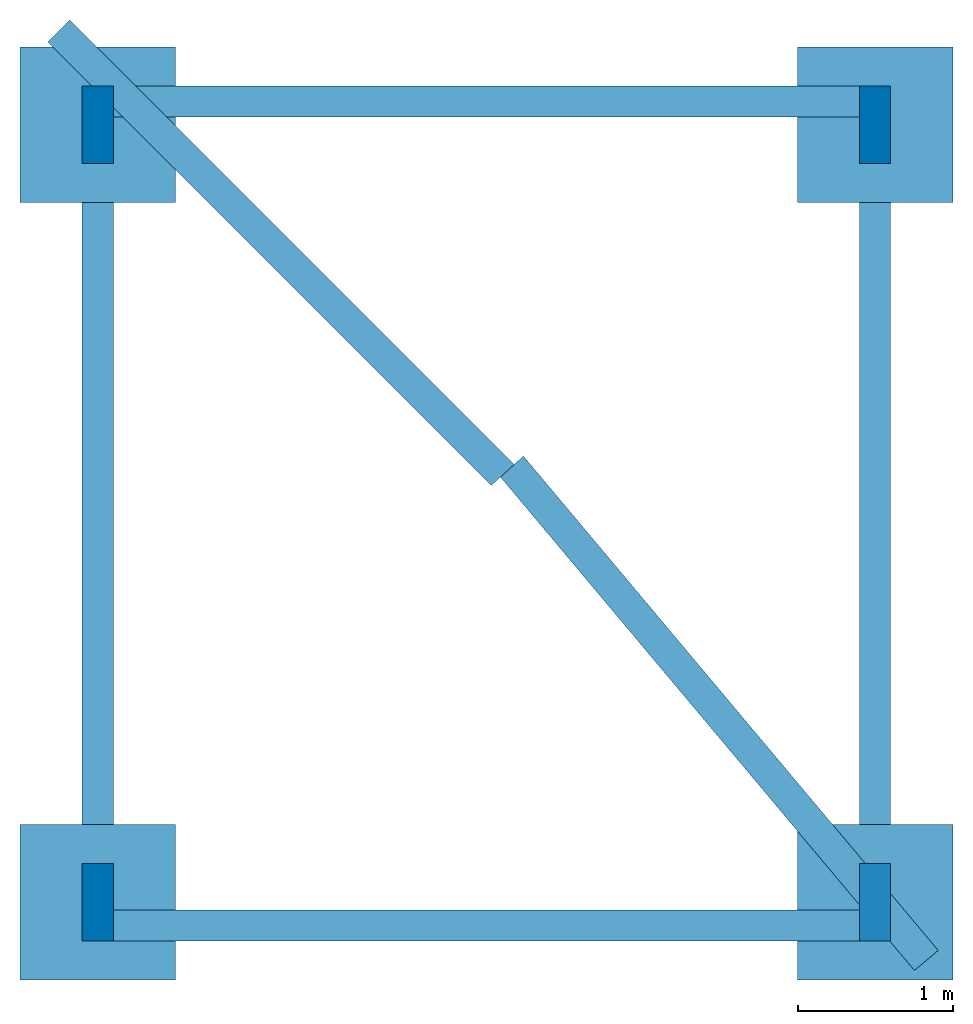
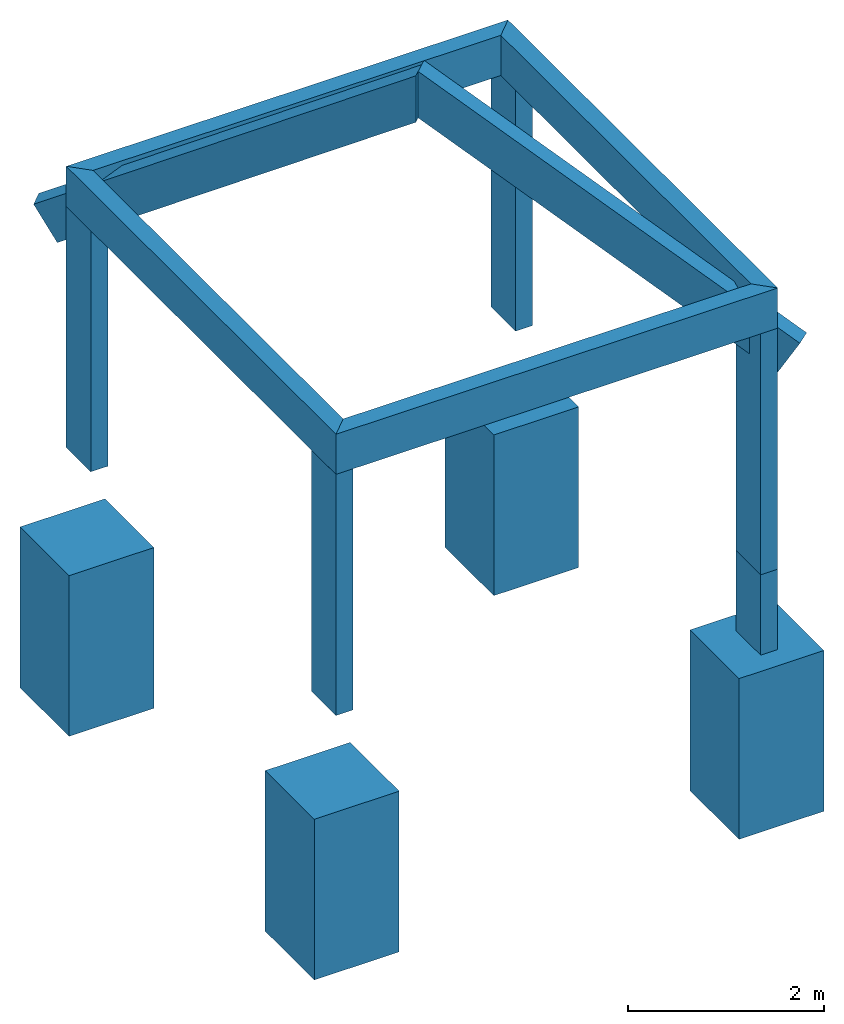
# One storey: 6 beams, 5 columns, 4 footings.
"""IFC4 building model written with IfcOpenShell, lengths in metres."""

from ifc_helpers import new_model, entity, si_unit, converted_unit, frame, origin_with_axes, origin_2d_with_axis, place, context, subcontext, project, spatial, rectangle, extrude, clip, halfspace, polygons, source, transform, mapped, material, material_profile, profile_set, profile_usage, type_object, type_shapes, element, save


model = new_model("IFC4")

# Units and contexts
model_context = context("Model", 3, precision=1e-05, world=origin_with_axes())
plan_context = context("Plan", 2, precision=1e-05, world=origin_2d_with_axis())
body_context = subcontext(model_context, "Body", "Model", "MODEL_VIEW")
ifc_project = project(units=[si_unit("VOLUMEUNIT", "CUBIC_METRE"), si_unit("LENGTHUNIT", "METRE"), converted_unit("PLANEANGLEUNIT", "degree", entity("IfcReal", 0.0174532925199433), si_unit("PLANEANGLEUNIT", "RADIAN"), dimensions=[0, 0, 0, 0, 0, 0, 0]), si_unit("AREAUNIT", "SQUARE_METRE")], contexts=[model_context, plan_context])

# Site, building, storey
site_placement = place(None, origin_with_axes())
site = spatial("IfcSite", under=ifc_project, at=site_placement)
building_placement = place(site_placement, origin_with_axes())
building = spatial("IfcBuilding", under=site, at=building_placement, Name="Building")
storey_placement = place(building_placement, origin_with_axes())
storey = spatial("IfcBuildingStorey", under=building, at=storey_placement, Name="Storey")

# Footings
footing_type = type_object("IfcFootingType", Name="Cube", PredefinedType="CAISSON_FOUNDATION")
shared_shape = source(origin_with_axes(), body_context, "Body", "Tessellation", [
    polygons([(-0.5, -0.5, -1.0), (-0.5, 0.5, -1.0), (-0.5, -0.5, 1.0), (-0.5, 0.5, 1.0), (0.5, 0.5, -1.0), (0.5, 0.5, 1.0), (0.5, -0.5, -1.0), (0.5, -0.5, 1.0)], [[[3, 4, 2, 1]], [[8, 7, 5, 6]], [[8, 6, 4, 3]], [[2, 4, 6, 5]], [[1, 7, 8, 3]], [[7, 1, 2, 5]]]),
])
type_shapes(footing_type, [shared_shape])
for number, where, z_axis, x_axis, name in (
    (1, (0.0, 0.0, 1.0), (0.0, 0.0, 1.0), (1.0, 0.0, 0.0), "Footing"),
    (2, (0.0, 5.0, 1.0), (0.0, 0.0, 1.0), (1.0, 0.0, 0.0), "Footing"),
    (3, (5.0, 0.0, 1.0), (0.0, 0.0, 1.0), (1.0, 0.0, 0.0), "Footing"),
    (4, (5.0, 5.0, 1.0), (0.0, 0.0, 1.0), (1.0, 0.0, 0.0), "Footing"),
):
    element("IfcFooting", number, at=place(storey_placement, frame(where, z_axis=z_axis, x_axis=x_axis)), inside=storey, type_object=footing_type, Name=name, PredefinedType="NOTDEFINED", context=body_context, shape_type="MappedRepresentation", body=[
        mapped(shared_shape, transform((0.0, 0.0, 0.0), x_axis=(1.0, 0.0, 0.0), y_axis=(0.0, 1.0, 0.0), z_axis=(0.0, 0.0, 1.0), scale=1.0)),
    ])

# Columns
ifc_material = material()
ifc_material_profile_1 = material_profile(ifc_material, rectangle(XDim=0.200000002980232, YDim=0.5))
ifc_profile_set_1 = profile_set([ifc_material_profile_1])
ifc_profile_usage_1 = profile_usage(ifc_profile_set_1, cardinal=5)
column_type = type_object("IfcColumnType", PredefinedType="COLUMN", material=ifc_profile_set_1)
column_1_placement = place(storey_placement, frame((0.0, 0.0, 3.0), z_axis=(0.0, 0.0, 1.0), x_axis=(1.0, 0.0, 0.0)))
element("IfcColumn", 5, at=column_1_placement, inside=storey, type_object=column_type, material=ifc_profile_usage_1, Name="Column", PredefinedType="NOTDEFINED", context=body_context, shape_type="SweptSolid", body=[
    extrude(rectangle(XDim=0.200000002980232, YDim=0.5), origin_with_axes(), (0.0, 0.0, 1.0), 3.0),
])
ifc_profile_usage_2 = profile_usage(ifc_profile_set_1, cardinal=5)
column_2_placement = place(storey_placement, frame((0.0, 5.0, 3.0), z_axis=(0.0, 0.0, 1.0), x_axis=(1.0, 0.0, 0.0)))
element("IfcColumn", 6, at=column_2_placement, inside=storey, type_object=column_type, material=ifc_profile_usage_2, Name="Column", PredefinedType="NOTDEFINED", context=body_context, shape_type="SweptSolid", body=[
    extrude(rectangle(XDim=0.200000002980232, YDim=0.5), origin_with_axes(), (0.0, 0.0, 1.0), 3.0),
])
ifc_profile_usage_3 = profile_usage(ifc_profile_set_1, cardinal=5)
column_3_placement = place(storey_placement, frame((5.0, 5.0, 3.0), z_axis=(0.0, 0.0, 1.0), x_axis=(1.0, 0.0, 0.0)))
element("IfcColumn", 7, at=column_3_placement, inside=storey, type_object=column_type, material=ifc_profile_usage_3, Name="Column", PredefinedType="NOTDEFINED", context=body_context, shape_type="SweptSolid", body=[
    extrude(rectangle(XDim=0.200000002980232, YDim=0.5), origin_with_axes(), (0.0, 0.0, 1.0), 3.0),
])
ifc_profile_usage_4 = profile_usage(ifc_profile_set_1, cardinal=5)
column_4_placement = place(storey_placement, frame((5.0, 0.0, 3.0), z_axis=(0.0, 0.0, 1.0), x_axis=(1.0, 0.0, 0.0)))
element("IfcColumn", 8, at=column_4_placement, inside=storey, type_object=column_type, material=ifc_profile_usage_4, Name="Column", PredefinedType="NOTDEFINED", context=body_context, shape_type="SweptSolid", body=[
    extrude(rectangle(XDim=0.200000002980232, YDim=0.5), origin_with_axes(), (0.0, 0.0, 1.0), 3.0),
])
ifc_profile_usage_5 = profile_usage(ifc_profile_set_1, cardinal=5)
column_5_placement = place(storey_placement, frame((5.0, 0.0, 0.0), z_axis=(0.0, 0.0, 1.0), x_axis=(1.0, 0.0, 0.0)))
element("IfcColumn", 9, at=column_5_placement, inside=storey, type_object=column_type, material=ifc_profile_usage_5, Name="Column", PredefinedType="NOTDEFINED", context=body_context, shape_type="SweptSolid", body=[
    extrude(rectangle(XDim=0.200000002980232, YDim=0.5), origin_with_axes(), (0.0, 0.0, 1.0), 3.0),
])

# Beams
ifc_material_profile_2 = material_profile(ifc_material, rectangle(XDim=0.200000002980232, YDim=0.5))
ifc_material_profile_3 = material_profile(ifc_material, rectangle(XDim=0.200000002980232, YDim=0.400000005960464))
ifc_profile_set_2 = profile_set([ifc_material_profile_2, ifc_material_profile_3])
ifc_profile_usage_6 = profile_usage(ifc_profile_set_2, cardinal=5)
beam_type = type_object("IfcBeamType", PredefinedType="BEAM", material=ifc_profile_set_2)
beam_1_placement = place(storey_placement, frame((-0.0999997854232788, -0.149999976158142, 6.25), z_axis=(1.0, -7.54979012640433e-08, 7.54979012640433e-08), x_axis=(7.54979012640433e-08, 1.0, 7.16093850883226e-15)))
element("IfcBeam", 10, at=beam_1_placement, inside=storey, type_object=beam_type, material=ifc_profile_usage_6, Name="Beam", PredefinedType="NOTDEFINED", context=body_context, shape_type="Clipping", body=[
    clip(clip(extrude(rectangle(XDim=0.200000002980232, YDim=0.5), origin_with_axes(), (0.0, 0.0, 1.0), 5.19999972123369), halfspace(frame((-0.0999999865889549, -5.25, 4.2865639215961e-07), z_axis=(0.70710688829422, -6.18172606436929e-08, -0.707106649875641), x_axis=(0.707106649875641, 6.18172606436929e-08, 0.70710688829422)), False)), halfspace(frame((-0.100000217556953, -5.24999952316284, 5.20000028610229), z_axis=(0.707106471061707, 5.33850723627438e-08, 0.707107126712799), x_axis=(0.707107126712799, -5.33851078898806e-08, -0.707106471061707)), False)),
])
ifc_profile_usage_7 = profile_usage(ifc_profile_set_2, cardinal=5)
beam_2_placement = place(storey_placement, frame((-0.0999978929758072, 5.15000057220459, 6.24999952316284), z_axis=(1.0, -7.54979012640433e-08, 7.54979012640433e-08), x_axis=(7.54979012640433e-08, 1.0, 7.16093850883226e-15)))
element("IfcBeam", 11, at=beam_2_placement, inside=storey, type_object=beam_type, material=ifc_profile_usage_7, Name="Beam", PredefinedType="NOTDEFINED", context=body_context, shape_type="Clipping", body=[
    clip(clip(extrude(rectangle(XDim=0.200000002980232, YDim=0.5), origin_with_axes(), (0.0, 0.0, 1.0), 5.19999880423903), halfspace(frame((0.0999998971819878, -5.24999952316284, 4.90255047225219e-07), z_axis=(-0.707107067108154, -6.18172322219834e-08, -0.707106530666351), x_axis=(-0.707106530666351, 6.18172890654023e-08, 0.707107067108154)), False)), halfspace(frame((0.0999998152256012, -5.24999904632568, 5.19999933242798), z_axis=(-0.707106649875641, 5.33850652573165e-08, 0.70710676908493), x_axis=(-0.70710676908493, -5.33851292061627e-08, -0.707106649875641)), False)),
])
ifc_profile_usage_8 = profile_usage(ifc_profile_set_2, cardinal=5)
beam_3_placement = place(storey_placement, frame((2.14576743928774e-06, 5.25000047683716, 6.24999809265137), z_axis=(-3.57627783387215e-07, -1.0, 3.13916473260178e-07), x_axis=(1.0, -3.57627726543797e-07, 1.62920713364656e-07)))
element("IfcBeam", 12, at=beam_3_placement, inside=storey, type_object=beam_type, material=ifc_profile_usage_8, Name="Beam", PredefinedType="NOTDEFINED", context=body_context, shape_type="Clipping", body=[
    clip(clip(extrude(rectangle(XDim=0.200000002980232, YDim=0.5), origin_with_axes(), (0.0, 0.0, 1.0), 5.50000052018665), halfspace(frame((-0.100000001490116, -5.24999809265137, -1.39474980187515e-06), z_axis=(0.707106351852417, 2.21972655367608e-07, -0.707107245922089), x_axis=(0.707107245922089, -2.21972356939659e-07, 0.707106351852417)), False)), halfspace(frame((-0.100000001490116, -5.24999952316284, 5.49999904632568), z_axis=(0.707106828689575, -2.21972456415642e-07, 0.707106709480286), x_axis=(0.707106709480286, 2.21972499048206e-07, -0.707106828689575)), False)),
])
ifc_profile_usage_9 = profile_usage(ifc_profile_set_2, cardinal=5)
beam_4_placement = place(storey_placement, frame((5.0, -0.249999761581421, 6.24999952316284), z_axis=(1.50995830949796e-07, 1.0, -3.13916473260178e-07), x_axis=(-1.0, 1.50995788317232e-07, -1.50995802528087e-07)))
element("IfcBeam", 13, at=beam_4_placement, inside=storey, type_object=beam_type, material=ifc_profile_usage_9, Name="Beam", PredefinedType="NOTDEFINED", context=body_context, shape_type="Clipping", body=[
    clip(clip(extrude(rectangle(XDim=0.200000002980232, YDim=0.5), origin_with_axes(), (0.0, 0.0, 1.0), 5.50000052018638), halfspace(frame((-0.100000068545341, -5.24999713897705, 5.50000238418579), z_axis=(0.707106828689575, 2.21972442204788e-07, 0.707106590270996), x_axis=(0.707106590270996, -2.21972555891625e-07, -0.707106828689575)), False)), halfspace(frame((-0.0999999418854713, -5.24999856948853, 1.63434594924183e-06), z_axis=(0.707107067108154, -2.21972356939659e-07, -0.707106530666351), x_axis=(0.707106530666351, 2.21972527469916e-07, 0.707107067108154)), False)),
])
ifc_profile_usage_10 = profile_usage(ifc_profile_set_2, cardinal=5)
beam_5_placement = place(storey_placement, frame((5.2486743927002, -0.278331071138382, 5.65590381622314), z_axis=(-0.556670546531677, 0.663414120674133, 0.499999672174454), x_axis=(-0.766044437885284, -0.642787635326385, 1.36726834298884e-08)))
element("IfcBeam", 14, at=beam_5_placement, inside=storey, type_object=beam_type, material=ifc_profile_usage_10, Name="Beam.002", PredefinedType="NOTDEFINED", context=body_context, shape_type="Clipping", body=[
    clip(extrude(rectangle(XDim=0.200000002980232, YDim=0.5), origin_with_axes(), (0.0, 0.0, 1.0), 5.43259028500608), halfspace(frame((4.05882787704468, 0.250001788139343, 4.58307456970215), z_axis=(0.0436196029186249, -0.499523043632507, 0.865201711654663), x_axis=(-0.0251519810408354, -0.866300642490387, -0.4988893866539)), False)),
])
ifc_profile_usage_11 = profile_usage(ifc_profile_set_2, cardinal=5)
beam_6_placement = place(storey_placement, frame((-0.161610439419746, 5.51516628265381, 5.71650505065918), z_axis=(0.612372279167175, -0.612372279167175, 0.500000417232513), x_axis=(0.707106709480286, 0.707106709480286, 5.35943307511388e-08)))
element("IfcBeam", 15, at=beam_6_placement, inside=storey, type_object=beam_type, material=ifc_profile_usage_11, Name="Beam", PredefinedType="NOTDEFINED", context=body_context, shape_type="Clipping", body=[
    clip(extrude(rectangle(XDim=0.200000002980232, YDim=0.5), origin_with_axes(), (0.0, 0.0, 1.0), 5.30737304125973), halfspace(frame((-3.97932362556458, 0.250000506639481, 4.46186780929565), z_axis=(-0.0436192452907562, -0.499525189399719, 0.865200400352478), x_axis=(0.0251519680023193, -0.866299331188202, -0.498891621828079)), False)),
])

save(model, "model.ifc")
